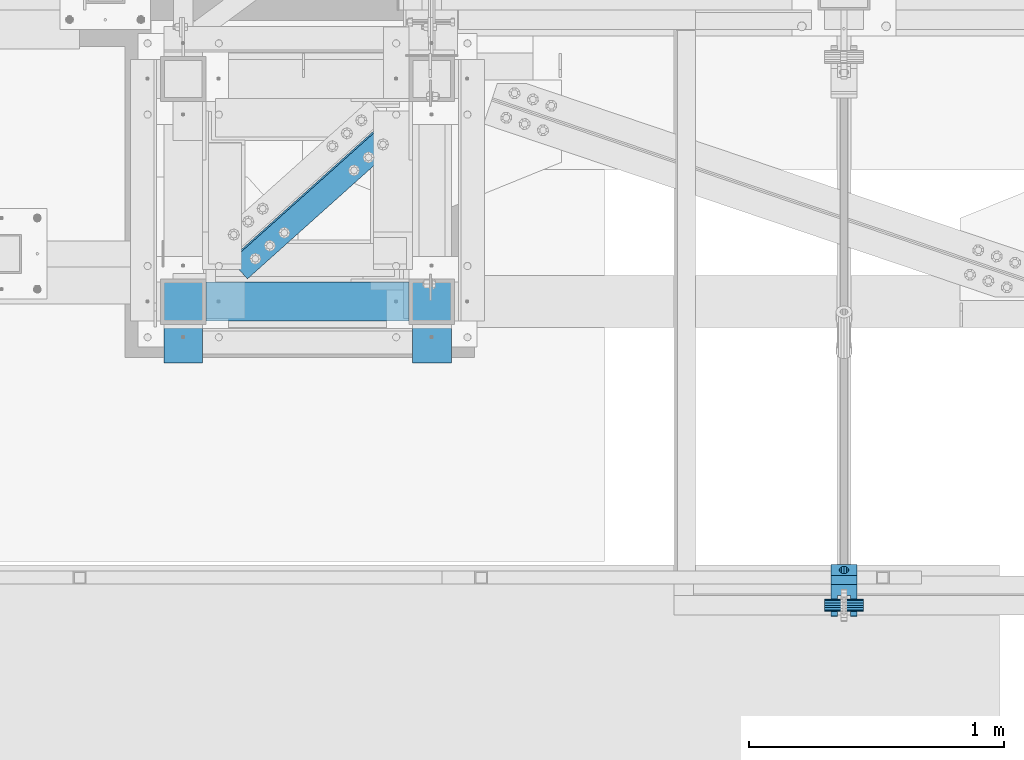
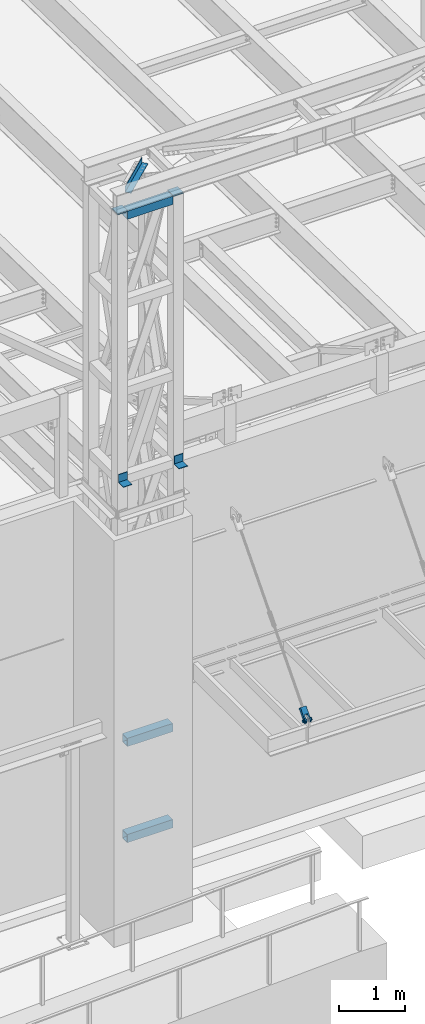
# One storey, part 1198 of 1763: 9 beams, 1 member, 4 elements without a shape of their own.
"""IFC2X3 building model written with IfcOpenShell, lengths in millimetres."""

from ifc_helpers import new_model, si_unit, frame, origin_with_axes, place, context, subcontext, project, spatial, faceted_brep, material, type_object, element, aggregate, save


model = new_model("IFC2X3")

# Units and contexts
model_context = context("Model", 3, precision=1e-05, world=origin_with_axes())
body_context = subcontext(model_context, "Body", "Model", "MODEL_VIEW")
ifc_project = project(units=[si_unit("LENGTHUNIT", "METRE", prefix="MILLI"), si_unit("AREAUNIT", "SQUARE_METRE"), si_unit("VOLUMEUNIT", "CUBIC_METRE"), si_unit("MASSUNIT", "GRAM", prefix="KILO"), si_unit("TIMEUNIT", "SECOND"), si_unit("PLANEANGLEUNIT", "RADIAN"), si_unit("SOLIDANGLEUNIT", "STERADIAN"), si_unit("THERMODYNAMICTEMPERATUREUNIT", "DEGREE_CELSIUS"), si_unit("LUMINOUSINTENSITYUNIT", "LUMEN")], contexts=[model_context])

# Site, building, storey
site_placement = place(None, origin_with_axes())
site = spatial("IfcSite", under=ifc_project, at=site_placement, CompositionType="ELEMENT")
building_placement = place(site_placement, origin_with_axes())
building = spatial("IfcBuilding", under=site, at=building_placement, Name="Undefined", CompositionType="ELEMENT")
storey_placement = place(building_placement, origin_with_axes())
storey = spatial("IfcBuildingStorey", under=building, at=storey_placement, Name="Undefined", CompositionType="ELEMENT", Elevation=0.0)

# Assembly, beam
assembly_1_placement = place(storey_placement, origin_with_axes())
assembly_1 = element("IfcElementAssembly", 1, at=assembly_1_placement, inside=storey, Name="ANGLE", AssemblyPlace="NOTDEFINED", PredefinedType="RIGID_FRAME")
ifc_material_1 = material(Name="STEEL/A36")
beam_type_1 = type_object("IfcBeamType", Name="L4X4X1/4", PredefinedType="NOTDEFINED")
beam_1_placement = place(assembly_1_placement, frame((-63176.5852932207, -14617.4392658022, 18672.175), z_axis=(0.667212485940871, -0.744867436933984, 0.0), x_axis=(-0.744867436933986, -0.667212485940869, 0.0)))
beam_1 = element("IfcBeam", 2, at=beam_1_placement, type_object=beam_type_1, material=ifc_material_1, Name="ANGLE", ObjectType="L4X4X1/4", context=body_context, shape_type="Brep", body=[
    faceted_brep([(238.038898020732, -50.7999999999993, -44.4499999995751), (238.038898020724, -50.7999999999993, -50.7999999995664), (1061.95371877369, -50.7999999999993, -50.7999999982567), (1061.9537187737, -50.7999999999993, -44.4499999982654), (238.038898020732, 44.4500000000007, -44.4499999995751), (1061.9537187737, 44.4500000000007, -44.4499999982654), (238.038898020834, 44.4500000000007, 50.8000000003085), (1061.9537187738, 44.4500000000007, 50.8000000016182), (238.038898020834, 50.7999999999993, 50.8000000003085), (1061.9537187738, 50.7999999999993, 50.8000000016182), (238.038898020724, 50.7999999999993, -50.7999999995664), (1061.95371877369, 50.7999999999993, -50.7999999982567)], [[[0, 1, 2, 3]], [[4, 0, 3, 5]], [[6, 4, 5, 7]], [[8, 6, 7, 9]], [[1, 0, 4, 6, 8, 10]], [[1, 10, 11, 2]], [[7, 5, 3, 2, 11, 9]], [[10, 8, 9, 11]]]),
])
aggregate(assembly_1, [beam_1])

# Assembly, beams
assembly_2_placement = place(storey_placement, origin_with_axes())
assembly_2 = element("IfcElementAssembly", 3, at=assembly_2_placement, inside=storey, Name="FRAME", AssemblyPlace="NOTDEFINED", PredefinedType="RIGID_FRAME")
ifc_material_2 = material()
beam_type_2 = type_object("IfcBeamType", Name="HSS6X6X3/8", PredefinedType="NOTDEFINED")
beam_2_placement = place(assembly_2_placement, frame((-64185.2277910131, -15452.7273151462, 18373.725), z_axis=(0.0, 0.0, 1.0), x_axis=(1.0, 0.0, 0.0)))
beam_2 = element("IfcBeam", 4, at=beam_2_placement, type_object=beam_type_2, material=ifc_material_2, Name="BEAM", ObjectType="HSS6X6X3/8", context=body_context, shape_type="Brep", body=[
    faceted_brep([(88.8999999999996, 66.6750000000029, -66.6749999999993), (88.8999999999996, -66.6750000000029, -66.6749999999993), (885.825195312507, -66.6749999999993, -66.6749999999993), (885.825158360378, 66.6749999998519, -66.6749999999993), (88.8999999999996, -66.6750000000029, 66.6749999999993), (885.825195312507, -66.6749999999993, 66.6749999999993), (88.8999999999996, 66.6750000000029, 66.6749999999993), (885.825158360378, 66.6749999998519, 66.6749999999993), (88.8999999999996, 76.1999999999971, -76.2000000000007), (88.8999999999996, 76.1999999999971, 76.2000000000007), (885.825180982218, 76.1999999998425, 76.2000000000007), (885.825180982218, 76.1999999998425, -76.2000000000007), (88.8999999999996, -76.1999999999971, 76.2000000000007), (885.825195312507, -76.2000000000007, 76.2000000000007), (88.8999999999996, -76.1999999999971, -76.2000000000007), (885.825195312507, -76.2000000000007, -76.2000000000007)], [[[0, 1, 2, 3]], [[1, 4, 5, 2]], [[4, 6, 7, 5]], [[6, 0, 3, 7]], [[8, 9, 10, 11]], [[9, 12, 13, 10]], [[12, 14, 15, 13]], [[14, 8, 11, 15]], [[13, 15, 11, 10], [5, 7, 3, 2]], [[14, 12, 9, 8], [6, 4, 1, 0]]]),
])
beam_3_placement = place(assembly_2_placement, frame((-64185.2277910131, -15452.7273151462, 8623.3), z_axis=(0.0, 0.0, 1.0), x_axis=(1.0, 0.0, 0.0)))
beam_3 = element("IfcBeam", 5, at=beam_3_placement, type_object=beam_type_2, material=ifc_material_2, Name="BEAM", ObjectType="HSS6X6X3/8", context=body_context, shape_type="Brep", body=[
    faceted_brep([(88.8999999999996, 66.6750000000029, -66.6749999999993), (88.8999999999996, -66.6750000000029, -66.6749999999993), (885.825195312507, -66.6749999999993, -66.6749999999993), (885.825158360378, 66.6749999998519, -66.6749999999993), (88.8999999999996, -66.6750000000029, 66.6749999999993), (885.825195312507, -66.6749999999993, 66.6749999999993), (88.8999999999996, 66.6750000000029, 66.6749999999993), (885.825158360378, 66.6749999998519, 66.6749999999993), (88.8999999999996, 76.1999999999971, -76.2000000000007), (88.8999999999996, 76.1999999999971, 76.2000000000007), (885.825180982218, 76.1999999998425, 76.2000000000007), (885.825180982218, 76.1999999998425, -76.2000000000007), (88.8999999999996, -76.1999999999971, 76.2000000000007), (885.825195312507, -76.2000000000007, 76.2000000000007), (88.8999999999996, -76.1999999999971, -76.2000000000007), (885.825195312507, -76.2000000000007, -76.2000000000007)], [[[0, 1, 2, 3]], [[1, 4, 5, 2]], [[4, 6, 7, 5]], [[6, 0, 3, 7]], [[8, 9, 10, 11]], [[9, 12, 13, 10]], [[12, 14, 15, 13]], [[14, 8, 11, 15]], [[13, 15, 11, 10], [5, 7, 3, 2]], [[14, 12, 9, 8], [6, 4, 1, 0]]]),
])
beam_4_placement = place(assembly_2_placement, frame((-64185.2277910131, -15452.7273151462, 6845.3), z_axis=(0.0, 0.0, 1.0), x_axis=(1.0, 0.0, 0.0)))
beam_4 = element("IfcBeam", 6, at=beam_4_placement, type_object=beam_type_2, material=ifc_material_2, Name="BEAM", ObjectType="HSS6X6X3/8", context=body_context, shape_type="Brep", body=[
    faceted_brep([(88.8999999999996, 66.6750000000029, -66.6749999999993), (88.8999999999996, -66.6750000000029, -66.6749999999993), (885.825195312507, -66.6749999999993, -66.6749999999993), (885.825158360378, 66.6749999998519, -66.6749999999993), (88.8999999999996, -66.6750000000029, 66.6749999999993), (885.825195312507, -66.6749999999993, 66.6749999999993), (88.8999999999996, 66.6750000000029, 66.6749999999993), (885.825158360378, 66.6749999998519, 66.6749999999993), (88.8999999999996, 76.1999999999971, -76.2000000000007), (88.8999999999996, 76.1999999999971, 76.2000000000007), (885.825180982218, 76.1999999998425, 76.2000000000007), (885.825180982218, 76.1999999998425, -76.2000000000007), (88.8999999999996, -76.1999999999971, 76.2000000000007), (885.825195312507, -76.2000000000007, 76.2000000000007), (88.8999999999996, -76.1999999999971, -76.2000000000007), (885.825195312507, -76.2000000000007, -76.2000000000007)], [[[0, 1, 2, 3]], [[1, 4, 5, 2]], [[4, 6, 7, 5]], [[6, 0, 3, 7]], [[8, 9, 10, 11]], [[9, 12, 13, 10]], [[12, 14, 15, 13]], [[14, 8, 11, 15]], [[13, 15, 11, 10], [5, 7, 3, 2]], [[14, 12, 9, 8], [6, 4, 1, 0]]]),
])
beam_type_3 = type_object("IfcBeamType", PredefinedType="NOTDEFINED")
beam_5_placement = place(assembly_2_placement, frame((-64185.2281907398, -15546.3898151462, 13649.325), z_axis=(1.0, 0.0, 0.0), x_axis=(0.0, 0.0, -1.0)))
beam_5 = element("IfcBeam", 7, at=beam_5_placement, type_object=beam_type_3, material=ifc_material_1, Name="BENT_PLATE", context=body_context, shape_type="Brep", body=[
    faceted_brep([(0.0, -4.76250000000073, -76.1999999999971), (0.0, -4.76250000000073, 76.1999969482422), (0.0, 4.76250000000073, 76.1999969482422), (0.0, 4.76250000000073, -76.1999999999971), (152.399993896484, 4.76250000000073, 76.1999999999971), (152.399993896484, 4.76250000000073, -76.1999999999971), (142.874993896483, -4.76250000000073, -76.1999999999971), (142.874993896483, -4.76250000000073, 76.1999999999971), (152.399993896484, -147.637493896484, 76.1999999999971), (152.399993896484, -147.637493896484, -76.1999999999971), (142.874993896483, -147.637493896484, 76.1999999999971), (142.874993896483, -147.637493896484, -76.1999999999971)], [[[0, 1, 2, 3]], [[3, 2, 4, 5]], [[1, 0, 6, 7]], [[5, 4, 8, 9]], [[4, 2, 1, 7, 10, 8]], [[7, 6, 11, 10]], [[6, 0, 3, 5, 9, 11]], [[10, 11, 9, 8]]]),
])
beam_6_placement = place(assembly_2_placement, frame((-63210.5029954273, -15546.3898151462, 13649.325), z_axis=(1.0, 0.0, 0.0), x_axis=(0.0, 0.0, -1.0)))
beam_6 = element("IfcBeam", 8, at=beam_6_placement, type_object=beam_type_3, material=ifc_material_1, Name="BENT_PLATE", context=body_context, shape_type="Brep", body=[
    faceted_brep([(0.0, -4.76250000000073, -76.1999999999971), (0.0, -4.76250000000073, 76.1999969482422), (0.0, 4.76250000000073, 76.1999969482422), (0.0, 4.76250000000073, -76.1999999999971), (152.399993896484, 4.76250000000073, 76.1999999999971), (152.399993896484, 4.76250000000073, -76.1999999999971), (142.874993896483, -4.76250000000073, -76.1999999999971), (142.874993896483, -4.76250000000073, 76.1999999999971), (152.399993896484, -147.637493896484, 76.1999999999971), (152.399993896484, -147.637493896484, -76.1999999999971), (142.874993896483, -147.637493896484, 76.1999999999971), (142.874993896483, -147.637493896484, -76.1999999999971)], [[[0, 1, 2, 3]], [[3, 2, 4, 5]], [[1, 0, 6, 7]], [[5, 4, 8, 9]], [[4, 2, 1, 7, 10, 8]], [[7, 6, 11, 10]], [[6, 0, 3, 5, 9, 11]], [[10, 11, 9, 8]]]),
])

# Assembly, beam
assembly_3_placement = place(storey_placement, origin_with_axes())
assembly_3 = element("IfcElementAssembly", 9, at=assembly_3_placement, inside=storey, Name="PIN", AssemblyPlace="NOTDEFINED", PredefinedType="RIGID_FRAME")
beam_type_4 = type_object("IfcBeamType", PredefinedType="NOTDEFINED")
beam_7_placement = place(assembly_3_placement, frame((-61670.6270083207, -16643.3525988321, 8839.20000000015), z_axis=(0.0, 0.0, 1.0), x_axis=(1.0, 0.0, 0.0)))
beam_7 = element("IfcBeam", 10, at=beam_7_placement, type_object=beam_type_4, material=ifc_material_2, Name="PIN", context=body_context, shape_type="Brep", body=[
    faceted_brep([(0.0, -25.4000000000015, 0.0), (0.0, -23.466540125788, -9.72015918207308), (152.400103102711, -23.466540125788, -9.72015918207308), (152.400103102711, -25.4000000000015, 0.0), (0.0, -17.9605122421381, -17.9605122421385), (152.400103102711, -17.9605122421381, -17.9605122421385), (0.0, -9.72015918207398, -23.4665401257867), (152.400103102711, -9.72015918207398, -23.4665401257867), (0.0, 0.0, -25.4000000000001), (152.400103102711, 0.0, -25.4000000000001), (0.0, 9.72015918207398, -23.4665401257867), (152.400103102711, 9.72015918207398, -23.4665401257867), (0.0, 17.9605122421381, -17.9605122421385), (152.400103102711, 17.9605122421381, -17.9605122421385), (0.0, 23.466540125788, -9.72015918207308), (152.400103102711, 23.466540125788, -9.72015918207308), (0.0, 25.4000000000015, 0.0), (152.400103102711, 25.4000000000015, 0.0), (0.0, 23.466540125788, 9.72015918207308), (152.400103102711, 23.466540125788, 9.72015918207308), (0.0, 17.9605122421381, 17.9605122421385), (152.400103102711, 17.9605122421381, 17.9605122421385), (0.0, 9.72015918207398, 23.4665401257867), (152.400103102711, 9.72015918207398, 23.4665401257867), (0.0, 0.0, 25.4000000000001), (152.400103102711, 0.0, 25.4000000000001), (0.0, -9.72015918207398, 23.4665401257867), (152.400103102711, -9.72015918207398, 23.4665401257867), (0.0, -17.9605122421381, 17.9605122421385), (152.400103102711, -17.9605122421381, 17.9605122421385), (0.0, -23.466540125788, 9.72015918207308), (152.400103102711, -23.466540125788, 9.72015918207308)], [[[0, 1, 2, 3]], [[1, 4, 5, 2]], [[4, 6, 7, 5]], [[6, 8, 9, 7]], [[8, 10, 11, 9]], [[10, 12, 13, 11]], [[12, 14, 15, 13]], [[14, 16, 17, 15]], [[16, 18, 19, 17]], [[18, 20, 21, 19]], [[20, 22, 23, 21]], [[22, 24, 25, 23]], [[24, 26, 27, 25]], [[26, 28, 29, 27]], [[28, 30, 31, 29]], [[30, 0, 3, 31]], [[5, 7, 9, 11, 13, 15, 17, 19, 21, 23, 25, 27, 29, 31, 3, 2]], [[30, 28, 26, 24, 22, 20, 18, 16, 14, 12, 10, 8, 6, 4, 1, 0]]]),
])
aggregate(assembly_3, [beam_7])

# Assembly, member
assembly_4_placement = place(storey_placement, origin_with_axes())
assembly_4 = element("IfcElementAssembly", 11, at=assembly_4_placement, inside=storey, Name="HANGER ROD", AssemblyPlace="NOTDEFINED", PredefinedType="RIGID_FRAME")
member_type = type_object("IfcMemberType", PredefinedType="NOTDEFINED")
member_placement = place(assembly_4_placement, frame((-61594.4270083209, -16672.6598761127, 8805.7801660124), z_axis=(-1.0, 0.0, 0.0), x_axis=(0.0, 0.659331589097062, 0.75185228311068)))
member = element("IfcMember", 12, at=member_placement, type_object=member_type, material=ifc_material_1, context=body_context, shape_type="Brep", body=[
    faceted_brep([(254.000002114522, 9.52500000169675, 16.4977839419953), (134.273330688089, 9.52500000160944, 16.4977839419953), (134.273330688083, 16.4977839436942, 9.52499999989959), (254.000002182145, 16.4977839437852, 9.52499999989959), (134.273330688081, 19.0500000015963, -1.01863406598568e-10), (254.000002023278, 19.0500000016909, -1.01863406598568e-10), (134.273330688083, 16.4977839436942, -9.52500000010332), (254.000001680489, 16.4977839437852, -9.52500000010332), (134.273330688089, 9.52500000160944, -16.497783942199), (254.000001245629, 9.52500000169675, -16.497783942199), (134.273330688098, 1.61890056915581e-09, -19.0500000001048), (254.000000835218, 1.70985003933311e-09, -19.0500000001048), (134.273330688103, -9.52499999837164, -16.497783942199), (254.000000559224, -9.52499999827705, -16.497783942199), (134.273330688109, -16.4977839404564, -9.52500000010332), (254.000000491603, -16.4977839403655, -9.52500000010332), (134.273330688112, -19.0499999983585, -1.01863406598568e-10), (254.000000650468, -19.0499999982676, -1.01863406598568e-10), (134.273330688109, -16.4977839404564, 9.52499999989959), (254.000000993259, -16.4977839403655, 9.52499999989959), (134.273330688103, -9.52499999837164, 16.4977839419953), (254.000001428119, -9.52499999827705, 16.4977839419953), (134.273330688098, 1.61890056915581e-09, 19.049999999901), (254.00000183853, 1.70985003933311e-09, 19.049999999901), (253.999999999431, 28.5749978801541, -50.8000000000029), (254.000000624264, 28.5749978801541, 50.8000000000029), (254.000004725771, -28.5826898869382, 50.8000000000029), (253.999999999356, -28.5826898869382, -50.8000000000029), (215.899998547231, 41.2749984764123, -50.8000000000029), (215.899998547231, 41.2749984764123, 50.8000000000029), (215.900005813682, 28.5749978523527, -50.8000000000029), (215.900005813682, 28.5749978523527, 50.8000000000029), (71.5070499061785, -35.274116161534, -50.8000000000029), (78.4980859437883, -28.5827170649136, -50.8000000000029), (78.4980859437883, -28.5827170649136, -25.3999992370664), (71.5070499061785, -35.274116161534, -25.3999992370664), (63.2335594872948, -40.2939531148404, -50.8000000000029), (63.2335594872948, -40.2939531148404, -25.3999992370664), (54.0697628809667, -43.4042969072325, -50.8000000000029), (54.0697628809667, -43.4042969072325, -25.3999992370664), (44.4500007625898, -44.4499999999498, -50.8000000000029), (44.4500007625898, -44.4500001906781, -25.3999992370664), (27.4397222623497, -41.066445304652, -50.8000000000029), (27.4397222623497, -41.066445304652, -25.3999992370664), (13.0191044786457, -31.4308962839314, -50.8000000000029), (13.0191044786457, -31.4308962839314, -25.3999992370664), (3.38355545789955, -17.0102785002382, -50.8000000000029), (3.38355545789955, -17.0102785002382, -25.3999992370664), (0.0, 0.0, -50.7999992370605), (0.0, 0.0, -25.4000000000001), (3.38355373177319, 17.0102772902901, -50.8000000000029), (3.38355373177319, 17.0102772902901, -25.3999992370664), (13.0191026972475, 31.4308957019275, -50.8000000000029), (13.0191026972475, 31.4308957019275, -25.3999992370664), (27.4397209215654, 41.0664449477481, -50.8000000000029), (27.4397209215654, 41.0664449477481, -25.3999992370664), (44.4500000032872, 44.4500000000189, -50.8000000000029), (44.4500000032872, 44.4500000003973, -25.3999992370664), (54.0697566428225, 43.3965760804131, -50.8000000000029), (54.0697566428225, 43.3965760804131, -25.3999992370664), (63.2335536975006, 40.2862336089929, -50.8000000000029), (63.2335536975006, 40.2862336089929, -25.3999992370664), (71.507044839982, 35.2663978483215, -50.8000000000029), (71.507044839982, 35.2663978483215, -25.3999992370664), (78.49808184214, 28.5749997594721, -50.8000000000029), (78.49808184214, 28.5749997594721, -25.3999992370664), (78.49808184214, 28.5749997594721, 50.8000000000029), (134.273330688678, 28.5749989853175, -25.3999992370664), (134.273330688678, 28.5749989853175, 25.3999999999942), (78.49808184214, 28.5749997594721, 25.3999999999942), (71.507044839982, 35.2663978483215, 50.8000000000029), (71.507044839982, 35.2663978483215, 25.3999999999942), (63.2335536975006, 40.2862336089929, 50.8000000000029), (63.2335536975006, 40.2862336089929, 25.3999999999942), (54.0697566428225, 43.3965760804131, 50.8000000000029), (54.0697566428225, 43.3965760804131, 25.3999999999942), (44.4500000032872, 44.4500000015396, 50.8000000000029), (44.450000003289, 44.4500000011612, 25.3999999999942), (27.4397209215654, 41.0664449477481, 50.8000000000029), (27.4397209215654, 41.0664449477481, 25.3999999999942), (13.0191026972475, 31.4308957019275, 50.8000000000029), (13.0191026972475, 31.4308957019275, 25.3999999999942), (3.38355373177319, 17.0102772902901, 50.8000000000029), (3.38355373177319, 17.0102772902901, 25.3999999999942), (0.0, 0.0, 50.7999992370605), (0.0, 0.0, 25.4000000000001), (3.38355545789955, -17.0102785002382, 50.8000000000029), (3.38355545789955, -17.0102785002382, 25.3999999999942), (13.0191044786457, -31.4308962839314, 50.8000000000029), (13.0191044786457, -31.4308962839314, 25.3999999999942), (27.4397222623497, -41.066445304652, 50.8000000000029), (27.4397222623497, -41.066445304652, 25.3999999999942), (44.4500007625898, -44.4500007628594, 50.8000000000029), (44.4500007625898, -44.4500005721347, 25.3999999999942), (54.0697628809667, -43.4042969072325, 50.8000000000029), (54.0697628809667, -43.4042969072325, 25.3999999999942), (63.2335594872948, -40.2939531148404, 50.8000000000029), (63.2335594872948, -40.2939531148404, 25.3999999999942), (71.5070499061785, -35.274116161534, 50.8000000000029), (71.5070499061785, -35.274116161534, 25.3999999999942), (78.4980859437883, -28.5827170649136, 50.8000000000029), (78.4980859437883, -28.5827170649136, 25.3999999999942), (215.900009915221, -28.5826953512624, 50.8000000000029), (215.900004479429, -41.2826959753438, 50.8000000000029), (68.3213099888762, -20.9337779588823, 50.8000000000029), (58.493204713217, -28.4754438363161, 50.8000000000029), (46.5271488219641, -31.681981520971, 50.8000000000029), (34.2448658519861, -30.0652247177059, 50.8000000000029), (23.5162220462953, -23.8713099938795, 50.8000000000029), (15.9745561689124, -14.0432047182112, 50.8000000000029), (12.7680184842902, -2.07714882693108, 50.8000000000029), (14.3847752875827, 10.2051341430815, 50.8000000000029), (20.5786900114208, 20.933777948816, 50.8000000000029), (30.4067952870791, 28.4754438262462, 50.8000000000029), (42.3728511783329, 31.6819815109047, 50.8000000000029), (54.65513414831, 30.0652247076396, 50.8000000000029), (65.3837779539981, 23.8713099838096, 50.8000000000029), (72.9254438313847, 14.0432047081449, 50.8000000000029), (76.1319815160032, 2.07714881686115, 50.8000000000029), (74.5152247127153, -10.2051341531514, 50.8000000000029), (68.3213099888762, -20.9337779588823, 25.3999999999942), (58.493204713217, -28.4754438363161, 25.3999999999942), (46.5271488219641, -31.681981520971, 25.3999999999942), (34.2448658519861, -30.0652247177059, 25.3999999999942), (23.5162220462953, -23.8713099938795, 25.3999999999942), (15.9745561689124, -14.0432047182112, 25.3999999999942), (12.7680184842902, -2.07714882693108, 25.3999999999942), (14.3847752875827, 10.2051341430815, 25.3999999999942), (20.5786900114208, 20.933777948816, 25.3999999999942), (30.4067952870791, 28.4754438262462, 25.3999999999942), (42.3728511783329, 31.6819815109047, 25.3999999999942), (54.65513414831, 30.0652247076396, 25.3999999999942), (65.3837779539981, 23.8713099838096, 25.3999999999942), (72.9254438313847, 14.0432047081449, 25.3999999999942), (76.1319815160032, 2.07714881686115, 25.3999999999942), (74.5152247127153, -10.2051341531514, 25.3999999999942), (134.273330688533, -28.5827082507421, 25.3999999999942), (215.900009915221, -28.5826953512624, -50.8000000000029), (134.273330688533, -28.5827082507421, -25.3999992370664), (215.900004479429, -41.2826959753438, -50.8000000000029), (65.3837779539981, 23.8713099838096, -50.8000000000029), (54.65513414831, 30.0652247076396, -50.8000000000029), (42.3728511783329, 31.6819815109047, -50.8000000000029), (30.4067952870791, 28.4754438262462, -50.8000000000029), (20.5786900114208, 20.933777948816, -50.8000000000029), (14.3847752875827, 10.2051341430815, -50.8000000000029), (12.7680184842902, -2.07714882693108, -50.8000000000029), (15.9745561689124, -14.0432047182112, -50.8000000000029), (23.5162220462953, -23.8713099938795, -50.8000000000029), (34.2448658519861, -30.0652247177059, -50.8000000000029), (46.5271488219641, -31.681981520971, -50.8000000000029), (58.493204713217, -28.4754438363161, -50.8000000000029), (68.3213099888762, -20.9337779588823, -50.8000000000029), (74.5152247127153, -10.2051341531514, -50.8000000000029), (76.1319815160032, 2.07714881686115, -50.8000000000029), (72.9254438313847, 14.0432047081449, -50.8000000000029), (65.3837779539981, 23.8713099838096, -25.3999992370664), (54.65513414831, 30.0652247076396, -25.3999992370664), (42.3728511783329, 31.6819815109047, -25.3999992370664), (30.4067952870791, 28.4754438262462, -25.3999992370664), (20.5786900114208, 20.933777948816, -25.3999992370664), (14.3847752875827, 10.2051341430815, -25.3999992370664), (12.7680184842902, -2.07714882693108, -25.3999992370664), (15.9745561689124, -14.0432047182112, -25.3999992370664), (23.5162220462953, -23.8713099938795, -25.3999992370664), (34.2448658519861, -30.0652247177059, -25.3999992370664), (46.5271488219641, -31.681981520971, -25.3999992370664), (58.493204713217, -28.4754438363161, -25.3999992370664), (68.3213099888762, -20.9337779588823, -25.3999992370664), (74.5152247127153, -10.2051341531514, -25.3999992370664), (76.1319815160032, 2.07714881686115, -25.3999992370664), (72.9254438313847, 14.0432047081449, -25.3999992370664)], [[[0, 1, 2, 3]], [[3, 2, 4, 5]], [[5, 4, 6, 7]], [[7, 6, 8, 9]], [[9, 8, 10, 11]], [[11, 10, 12, 13]], [[13, 12, 14, 15]], [[15, 14, 16, 17]], [[17, 16, 18, 19]], [[19, 18, 20, 21]], [[21, 20, 22, 23]], [[23, 22, 1, 0]], [[24, 25, 26, 27], [3, 5, 7, 9, 11, 13, 15, 17, 19, 21, 23, 0]], [[25, 24, 28, 29]], [[29, 28, 30, 31]], [[32, 33, 34, 35]], [[36, 32, 35, 37]], [[38, 36, 37, 39]], [[40, 38, 39, 41]], [[42, 40, 41, 43]], [[44, 42, 43, 45]], [[46, 44, 45, 47]], [[48, 46, 47, 49]], [[50, 48, 49, 51]], [[52, 50, 51, 53]], [[54, 52, 53, 55]], [[56, 54, 55, 57]], [[58, 56, 57, 59]], [[60, 58, 59, 61]], [[62, 60, 61, 63]], [[64, 62, 63, 65]], [[66, 31, 30, 64, 65, 67, 68, 69]], [[70, 66, 69, 71]], [[72, 70, 71, 73]], [[74, 72, 73, 75]], [[76, 74, 75, 77]], [[78, 76, 77, 79]], [[80, 78, 79, 81]], [[82, 80, 81, 83]], [[84, 82, 83, 85]], [[86, 84, 85, 87]], [[88, 86, 87, 89]], [[90, 88, 89, 91]], [[92, 90, 91, 93]], [[94, 92, 93, 95]], [[96, 94, 95, 97]], [[98, 96, 97, 99]], [[100, 98, 99, 101]], [[25, 29, 31, 66, 70, 72, 74, 76, 78, 80, 82, 84, 86, 88, 90, 92, 94, 96, 98, 100, 102, 103, 26], [104, 105, 106, 107, 108, 109, 110, 111, 112, 113, 114, 115, 116, 117, 118, 119]], [[105, 104, 120, 121]], [[106, 105, 121, 122]], [[107, 106, 122, 123]], [[108, 107, 123, 124]], [[109, 108, 124, 125]], [[110, 109, 125, 126]], [[111, 110, 126, 127]], [[112, 111, 127, 128]], [[113, 112, 128, 129]], [[114, 113, 129, 130]], [[115, 114, 130, 131]], [[116, 115, 131, 132]], [[117, 116, 132, 133]], [[118, 117, 133, 134]], [[119, 118, 134, 135]], [[104, 119, 135, 120]], [[101, 99, 97, 95, 93, 91, 89, 87, 85, 83, 81, 79, 77, 75, 73, 71, 69, 68, 136], [134, 133, 132, 131, 130, 129, 128, 127, 126, 125, 124, 123, 122, 121, 120, 135]], [[34, 33, 137, 102, 100, 101, 136, 138]], [[102, 137, 139, 103]], [[26, 103, 139, 27]], [[137, 33, 32, 36, 38, 40, 42, 44, 46, 48, 50, 52, 54, 56, 58, 60, 62, 64, 30, 28, 24, 27, 139], [140, 141, 142, 143, 144, 145, 146, 147, 148, 149, 150, 151, 152, 153, 154, 155]], [[141, 140, 156, 157]], [[142, 141, 157, 158]], [[143, 142, 158, 159]], [[144, 143, 159, 160]], [[145, 144, 160, 161]], [[146, 145, 161, 162]], [[147, 146, 162, 163]], [[148, 147, 163, 164]], [[149, 148, 164, 165]], [[150, 149, 165, 166]], [[151, 150, 166, 167]], [[152, 151, 167, 168]], [[153, 152, 168, 169]], [[154, 153, 169, 170]], [[155, 154, 170, 171]], [[140, 155, 171, 156]], [[138, 67, 65, 63, 61, 59, 57, 55, 53, 51, 49, 47, 45, 43, 41, 39, 37, 35, 34], [170, 169, 168, 167, 166, 165, 164, 163, 162, 161, 160, 159, 158, 157, 156, 171]], [[136, 68, 67, 138], [18, 16, 14, 12, 10, 8, 6, 4, 2, 1, 22, 20]]]),
])
aggregate(assembly_4, [member])

# Beam
beam_type_5 = type_object("IfcBeamType", PredefinedType="NOTDEFINED")
beam_8_placement = place(assembly_2_placement, frame((-63210.5025957005, -15541.6273151462, 18459.45), z_axis=(1.0, 0.0, 0.0), x_axis=(0.0, 1.0, 0.0)))
beam_8 = element("IfcBeam", 13, at=beam_8_placement, type_object=beam_type_5, material=ifc_material_1, Name="PLATE", context=body_context, shape_type="Brep", body=[
    faceted_brep([(0.0, 9.52500000000146, -88.9000000000015), (0.0, 9.52500000000146, 88.9000000000015), (177.799999999999, 9.52500000000146, 88.9000000000015), (177.799999999999, 9.52500000000146, -88.9000000000015), (0.0, -9.52500000000146, 88.9000000000015), (177.799999999999, -9.52500000000146, 88.9000000000015), (0.0, -9.52500000000146, -88.9000000000015), (177.799999999999, -9.52500000000146, -88.9000000000015)], [[[0, 1, 2, 3]], [[1, 4, 5, 2]], [[4, 6, 7, 5]], [[6, 0, 3, 7]], [[5, 7, 3, 2]], [[6, 4, 1, 0]]]),
])

beam_9_placement = place(assembly_2_placement, frame((-64185.2277910131, -15541.6273151462, 18459.45), z_axis=(1.0, 0.0, 0.0), x_axis=(0.0, 1.0, 0.0)))
beam_9 = element("IfcBeam", 14, at=beam_9_placement, type_object=beam_type_5, material=ifc_material_1, Name="PLATE", context=body_context, shape_type="Brep", body=[
    faceted_brep([(0.0, 9.52500000000146, -88.9000000000015), (0.0, 9.52500000000146, 88.9000000000015), (177.799999999999, 9.52500000000146, 88.9000000000015), (177.799999999999, 9.52500000000146, -88.9000000000015), (0.0, -9.52500000000146, 88.9000000000015), (177.799999999999, -9.52500000000146, 88.9000000000015), (0.0, -9.52500000000146, -88.9000000000015), (177.799999999999, -9.52500000000146, -88.9000000000015)], [[[0, 1, 2, 3]], [[1, 4, 5, 2]], [[4, 6, 7, 5]], [[6, 0, 3, 7]], [[5, 7, 3, 2]], [[6, 4, 1, 0]]]),
])

aggregate(assembly_2, [beam_5, beam_6, beam_8, beam_9, beam_2, beam_3, beam_4])

save(model, "model.ifc")
